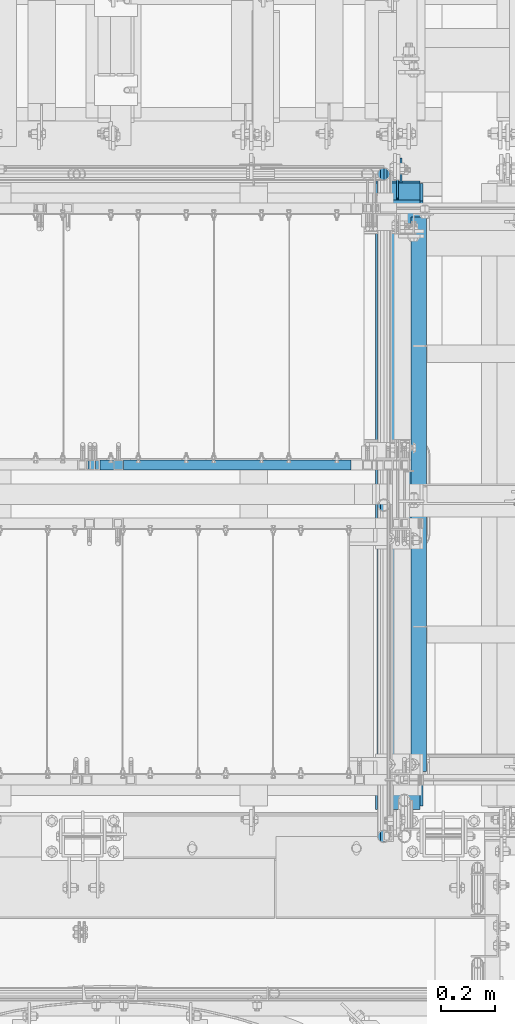
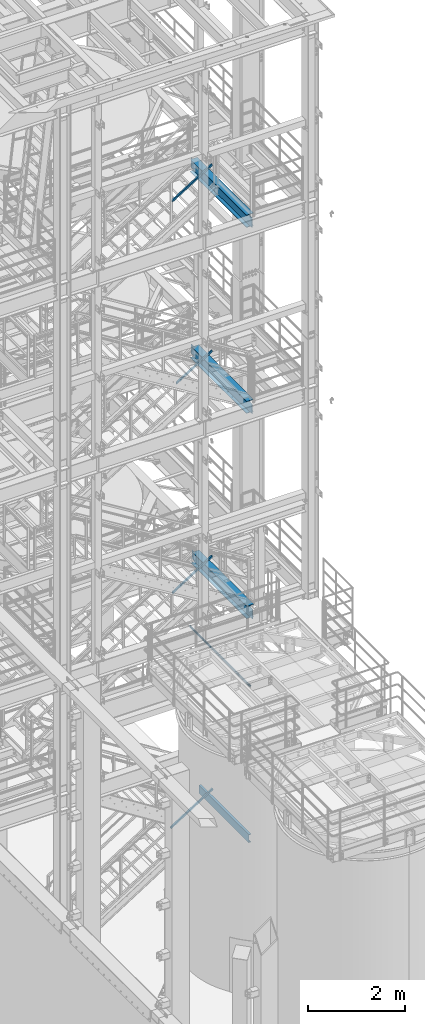
# One storey, part 984 of 1876: 5 beams, 4 members, 9 elements without a shape of their own.
"""IFC2X3 building model written with IfcOpenShell, lengths in millimetres."""

from ifc_helpers import new_model, si_unit, frame, origin_with_axes, place, context, subcontext, project, spatial, faceted_brep, material, type_object, element, aggregate, save


model = new_model("IFC2X3")

# Units and contexts
model_context = context("Model", 3, precision=1e-05, world=origin_with_axes())
body_context = subcontext(model_context, "Body", "Model", "MODEL_VIEW")
ifc_project = project(units=[si_unit("LENGTHUNIT", "METRE", prefix="MILLI"), si_unit("AREAUNIT", "SQUARE_METRE"), si_unit("VOLUMEUNIT", "CUBIC_METRE"), si_unit("MASSUNIT", "GRAM", prefix="KILO"), si_unit("TIMEUNIT", "SECOND"), si_unit("PLANEANGLEUNIT", "RADIAN"), si_unit("SOLIDANGLEUNIT", "STERADIAN"), si_unit("THERMODYNAMICTEMPERATUREUNIT", "DEGREE_CELSIUS"), si_unit("LUMINOUSINTENSITYUNIT", "LUMEN")], contexts=[model_context])

# Site, building, storey
site_placement = place(None, origin_with_axes())
site = spatial("IfcSite", under=ifc_project, at=site_placement, CompositionType="ELEMENT")
building_placement = place(site_placement, origin_with_axes())
building = spatial("IfcBuilding", under=site, at=building_placement, Name="Undefined", CompositionType="ELEMENT")
storey_placement = place(building_placement, origin_with_axes())
storey = spatial("IfcBuildingStorey", under=building, at=storey_placement, Name="Undefined", CompositionType="ELEMENT", Elevation=0.0)

# Assembly, beam
assembly_1_placement = place(storey_placement, origin_with_axes())
assembly_1 = element("IfcElementAssembly", 1, at=assembly_1_placement, inside=storey, Name="RAIL", AssemblyPlace="NOTDEFINED", PredefinedType="RIGID_FRAME")
ifc_material_1 = material()
beam_type_1 = type_object("IfcBeamType", Name="PIPE1-1/2SCH40", PredefinedType="NOTDEFINED")
beam_1_placement = place(assembly_1_placement, frame((6197.59999999994, -7136.13000000001, 6207.125), z_axis=(0.0, 0.0, -1.0), x_axis=(0.0, 1.0, 0.0)))
beam_1 = element("IfcBeam", 2, at=beam_1_placement, type_object=beam_type_1, material=ifc_material_1, Name="RAIL", ObjectType="PIPE1-1/2SCH40", context=body_context, shape_type="Brep", body=[
    faceted_brep([(24.1300000000001, -20.4469999999999, 0.0), (34.3535000000002, -17.7076214311803, 10.2235000000001), (2471.35649885447, -17.7076214311801, 10.2235000000001), (2481.57999885447, -20.4470000000001, 0.0), (41.8376214311802, -10.2235000000001, 17.7076214311819), (2463.87237742329, -10.2235000000001, 17.7076214311801), (44.5770000000002, 0.0, 20.4470000000001), (2461.13299885447, 0.0, 20.4470000000001), (41.8376214311802, 10.2235000000001, 17.7076214311819), (2463.87237742329, 10.2235000000001, 17.7076214311801), (34.3535000000002, 17.7076214311803, 10.2235000000001), (2471.35649885447, 17.7076214311801, 10.2235000000001), (24.1300000000001, 20.4469999999999, 0.0), (2481.57999885447, 20.4470000000001, 0.0), (13.9065000000001, 17.7076214311803, -10.2235000000001), (2491.80349885447, 17.7076214311801, -10.2235000000001), (6.42237856882002, 10.2235000000001, -17.7076214311819), (2499.28762028565, 10.2235000000001, -17.7076214311801), (3.68299999999999, 0.0, -20.4470000000001), (2502.02699885447, 0.0, -20.4470000000001), (6.42237856882002, -10.2235000000001, -17.7076214311819), (2499.28762028565, -10.2235000000001, -17.7076214311801), (13.9065000000001, -17.7076214311803, -10.2235000000001), (2491.80349885447, -17.7076214311801, -10.2235000000001), (24.1299999999854, -24.1299999999992, 0.0), (12.0650000000064, -20.8971929933177, -12.0649999999987), (2493.64499885447, -20.8971929933186, -12.0649999999996), (2481.57999885447, -24.1300000000001, 0.0), (3.23280700668147, -12.0650000000001, -20.8971929933177), (2502.47719184779, -12.0649999999996, -20.8971929933186), (-1.45519152283669e-11, 0.0, -24.130000000001), (2505.70999885447, 0.0, -24.1300000000001), (3.23280700668147, 12.0650000000001, -20.8971929933177), (2502.47719184779, 12.0649999999996, -20.8971929933186), (12.0650000000064, 20.8971929933177, -12.0649999999987), (2493.64499885447, 20.8971929933186, -12.0649999999996), (24.1300000000047, 24.1299999999992, 0.0), (2481.57999885447, 24.1300000000001, 0.0), (36.1949999999997, 20.8971929933184, 12.0649999999987), (2469.51499885447, 20.8971929933186, 12.0649999999996), (45.0271929933187, 12.0650000000001, 20.8971929933177), (2460.68280586115, 12.0649999999996, 20.8971929933186), (48.2600000000002, 0.0, 24.130000000001), (2457.44999885447, 0.0, 24.1300000000001), (45.0271929933187, -12.0650000000001, 20.8971929933177), (2460.68280586115, -12.0649999999996, 20.8971929933186), (36.1949999999997, -20.8971929933184, 12.0649999999987), (2469.51499885447, -20.8971929933186, 12.0649999999996)], [[[0, 1, 2, 3]], [[1, 4, 5, 2]], [[4, 6, 7, 5]], [[6, 8, 9, 7]], [[8, 10, 11, 9]], [[10, 12, 13, 11]], [[12, 14, 15, 13]], [[14, 16, 17, 15]], [[16, 18, 19, 17]], [[18, 20, 21, 19]], [[20, 22, 23, 21]], [[22, 0, 3, 23]], [[24, 25, 26, 27]], [[25, 28, 29, 26]], [[28, 30, 31, 29]], [[30, 32, 33, 31]], [[32, 34, 35, 33]], [[34, 36, 37, 35]], [[36, 38, 39, 37]], [[38, 40, 41, 39]], [[40, 42, 43, 41]], [[42, 44, 45, 43]], [[44, 46, 47, 45]], [[46, 24, 27, 47]], [[29, 31, 33, 35, 37, 39, 41, 43, 45, 47, 27, 26], [5, 7, 9, 11, 13, 15, 17, 19, 21, 23, 3, 2]], [[46, 44, 42, 40, 38, 36, 34, 32, 30, 28, 25, 24], [22, 20, 18, 16, 14, 12, 10, 8, 6, 4, 1, 0]]]),
])
aggregate(assembly_1, [beam_1])

assembly_2_placement = place(storey_placement, origin_with_axes())
assembly_2 = element("IfcElementAssembly", 3, at=assembly_2_placement, inside=storey, Name="STRINGER", AssemblyPlace="NOTDEFINED", PredefinedType="RIGID_FRAME")
ifc_material_2 = material(Name="STEEL/A36")
beam_type_2 = type_object("IfcBeamType", Name="C8X11.5", PredefinedType="NOTDEFINED")
beam_2_placement = place(assembly_2_placement, frame((6327.77500038161, -6883.40000113304, 2196.42941810345), z_axis=(0.0, 0.0, 1.0), x_axis=(0.0, 1.0, 0.0)))
beam_2 = element("IfcBeam", 4, at=beam_2_placement, type_object=beam_type_2, material=ifc_material_2, Name="STRINGER", ObjectType="C8X11.5", context=body_context, shape_type="Brep", body=[
    faceted_brep([(12.7000000000007, 28.5749999999998, -101.6), (12.7000000000007, 28.5749999999998, 101.6), (2070.09999991865, 28.5749999999998, 101.6), (2070.09999991865, 28.5749999999998, -101.6), (12.7000000000007, -28.5749999999998, 101.6), (2070.09999991865, -28.5749999999998, 101.6), (12.7000000000007, -28.5749999999998, 96.8355949999996), (2070.09999991865, -28.5749999999998, 96.835595), (12.7000000000007, 22.2250000000004, 88.3723149999996), (2070.09999991865, 22.2250000000004, 88.3723150000001), (12.7000000000007, 22.2250000000004, -88.3723149999996), (2070.09999991865, 22.2250000000004, -88.3723150000001), (12.7000000000007, -28.5749999999998, -96.8355949999996), (2070.09999991865, -28.5749999999998, -96.835595), (12.7000000000007, -28.5749999999998, -101.6), (2070.09999991865, -28.5749999999998, -101.6)], [[[0, 1, 2, 3]], [[1, 4, 5, 2]], [[4, 6, 7, 5]], [[6, 8, 9, 7]], [[8, 10, 11, 9]], [[10, 12, 13, 11]], [[12, 14, 15, 13]], [[14, 0, 3, 15]], [[5, 7, 9, 11, 13, 15, 3, 2]], [[14, 12, 10, 8, 6, 4, 1, 0]]]),
])
aggregate(assembly_2, [beam_2])

# Assembly, member
assembly_3_placement = place(storey_placement, origin_with_axes())
assembly_3 = element("IfcElementAssembly", 5, at=assembly_3_placement, inside=storey, Name="RAIL", AssemblyPlace="NOTDEFINED", PredefinedType="RIGID_FRAME")
ifc_material_3 = material()
member_type = type_object("IfcMemberType", Name="HSS1-1/2X1-1/2X1/8", PredefinedType="NOTDEFINED")
member_1_placement = place(assembly_3_placement, frame((5080.00000001329, -5734.05000114554, 2193.12876147334), z_axis=(-0.53569741975471, 0.0, 0.844410015613355), x_axis=(0.844410015326383, 0.0, 0.535697420207059)))
member_1 = element("IfcMember", 6, at=member_1_placement, type_object=member_type, material=ifc_material_3, Name="RAIL", ObjectType="HSS1-1/2X1-1/2X1/8", context=body_context, shape_type="Brep", body=[
    faceted_brep([(12.4889602027924, 15.8749992829999, -15.8749992829981), (12.4889602027924, -15.8749992829999, -15.8749992829981), (1198.5961562867, -15.8749992829999, -15.874999282681), (1198.5961562867, 15.8749992829999, -15.874999282681), (32.6312986338025, -15.8749992829999, 15.8749992830109), (1207.81774592547, -15.8749992829999, 15.8749992833251), (32.6312986338025, 15.8749992829999, 15.8749992830109), (1207.81774592547, 15.8749992829999, 15.8749992833251), (10.4747262991696, 19.0499992349996, -19.0499992349991), (34.6455325374254, 19.0499992349996, 19.049999235012), (1208.73990491706, 19.0499992349996, 19.0499992353258), (1197.67399729511, 19.0499992349996, -19.0499992346821), (34.6455325374254, -19.0499992349996, 19.049999235012), (1208.73990491706, -19.0499992349996, 19.0499992353258), (10.4747262991696, -19.0499992349996, -19.0499992349991), (1197.67399729511, -19.0499992349996, -19.0499992346821)], [[[0, 1, 2, 3]], [[1, 4, 5, 2]], [[4, 6, 7, 5]], [[6, 0, 3, 7]], [[8, 9, 10, 11]], [[9, 12, 13, 10]], [[12, 14, 15, 13]], [[14, 8, 11, 15]], [[13, 15, 11, 10], [5, 7, 3, 2]], [[14, 12, 9, 8], [6, 4, 1, 0]]]),
])
aggregate(assembly_3, [member_1])

assembly_4_placement = place(storey_placement, origin_with_axes())
assembly_4 = element("IfcElementAssembly", 7, at=assembly_4_placement, inside=storey, Name="RAIL", AssemblyPlace="NOTDEFINED", PredefinedType="RIGID_FRAME")
member_2_placement = place(assembly_4_placement, frame((5124.4499953538, -5734.05000114554, 8078.06590455734), z_axis=(-0.536875491934336, 0.0, 0.843661487896813), x_axis=(0.843661487896813, 0.0, 0.536875491934336)))
member_2 = element("IfcMember", 8, at=member_2_placement, type_object=member_type, material=ifc_material_3, Name="RAIL", ObjectType="HSS1-1/2X1-1/2X1/8", context=body_context, shape_type="Brep", body=[
    faceted_brep([(12.4778733370622, 15.8749992829999, -15.8749992829939), (12.4778733370622, -15.8749992829999, -15.8749992829939), (1129.22312611781, -15.8749992829999, -15.8749992825997), (1129.22312611781, 15.8749992829999, -15.8749992825997), (32.6824178653787, -15.8749992829999, 15.8749992830085), (1138.46874750438, -15.8749992829999, 15.8749992834), (32.6824178653787, 15.8749992829999, 15.8749992830085), (1138.46874750438, 15.8749992829999, 15.8749992834), (10.4574188235219, 19.0499992349996, -19.0499992349946), (34.7028723789208, 19.0499992349996, 19.0499992350083), (1139.39330967082, 19.0499992349996, 19.0499992353994), (1128.29856395138, 19.0499992349996, -19.0499992345995), (34.7028723789208, -19.0499992349996, 19.0499992350083), (1139.39330967082, -19.0499992349996, 19.0499992353994), (10.4574188235219, -19.0499992349996, -19.0499992349946), (1128.29856395138, -19.0499992349996, -19.0499992345995)], [[[0, 1, 2, 3]], [[1, 4, 5, 2]], [[4, 6, 7, 5]], [[6, 0, 3, 7]], [[8, 9, 10, 11]], [[9, 12, 13, 10]], [[12, 14, 15, 13]], [[14, 8, 11, 15]], [[13, 15, 11, 10], [5, 7, 3, 2]], [[14, 12, 9, 8], [6, 4, 1, 0]]]),
])
aggregate(assembly_4, [member_2])

assembly_5_placement = place(storey_placement, origin_with_axes())
assembly_5 = element("IfcElementAssembly", 9, at=assembly_5_placement, inside=storey, Name="RAIL", AssemblyPlace="NOTDEFINED", PredefinedType="RIGID_FRAME")
member_3_placement = place(assembly_5_placement, frame((5213.35000009579, -5734.05000114554, 13309.5615150425), z_axis=(-0.523953411146183, 0.0, 0.851746924237639), x_axis=(0.851746924237639, 0.0, 0.523953411146184)))
member_3 = element("IfcMember", 10, at=member_3_placement, type_object=member_type, material=ifc_material_3, Name="RAIL", ObjectType="HSS1-1/2X1-1/2X1/8", context=body_context, shape_type="Brep", body=[
    faceted_brep([(12.6002676416374, 15.8749992829999, -15.8749992830035), (12.6002676416374, -15.8749992829999, -15.8749992830035), (1013.61105050611, -15.8749992829999, -15.8749992832345), (1013.61105050611, 15.8749992829999, -15.8749992832345), (32.1313273721225, -15.8749992829999, 15.874999282998), (1022.5947403588, -15.8749992829999, 15.8749992827688), (32.1313273721225, 15.8749992829999, 15.874999282998), (1022.5947403588, 15.8749992829999, 15.8749992827688), (10.6471616099025, 19.0499992349996, -19.0499992350033), (34.0844334038557, 19.0499992349996, 19.0499992349978), (1023.49310937106, 19.0499992349996, 19.0499992347686), (1012.71268149385, 19.0499992349996, -19.0499992352343), (34.0844334038557, -19.0499992349996, 19.0499992349978), (1023.49310937106, -19.0499992349996, 19.0499992347686), (10.6471616099025, -19.0499992349996, -19.0499992350033), (1012.71268149385, -19.0499992349996, -19.0499992352343)], [[[0, 1, 2, 3]], [[1, 4, 5, 2]], [[4, 6, 7, 5]], [[6, 0, 3, 7]], [[8, 9, 10, 11]], [[9, 12, 13, 10]], [[12, 14, 15, 13]], [[14, 8, 11, 15]], [[13, 15, 11, 10], [5, 7, 3, 2]], [[14, 12, 9, 8], [6, 4, 1, 0]]]),
])
aggregate(assembly_5, [member_3])

assembly_6_placement = place(storey_placement, origin_with_axes())
assembly_6 = element("IfcElementAssembly", 11, at=assembly_6_placement, inside=storey, Name="RAIL", AssemblyPlace="NOTDEFINED", PredefinedType="RIGID_FRAME")
member_4_placement = place(assembly_6_placement, frame((5107.78124790234, -5734.05000114554, 17913.9321244588), z_axis=(-0.526627379729772, 0.0, 0.850096231563789), x_axis=(0.850096231563789, 0.0, 0.526627379729772)))
member_4 = element("IfcMember", 12, at=member_4_placement, type_object=member_type, material=ifc_material_3, Name="RAIL", ObjectType="HSS1-1/2X1-1/2X1/8", context=body_context, shape_type="Brep", body=[
    faceted_brep([(12.574799847971, 15.8749992829999, -15.8749992829671), (12.574799847971, -15.8749992829999, -15.8749992829671), (1139.87266300767, -15.8749992829999, -15.8749992813318), (1139.87266300767, 15.8749992829999, -15.8749992813318), (32.243653714735, -15.8749992829999, 15.8749992830344), (1148.91025696958, -15.8749992829999, 15.8749992846551), (32.243653714735, 15.8749992829999, 15.8749992830344), (1148.91025696958, 15.8749992829999, 15.8749992846551), (10.6079144021951, 19.0499992349996, -19.0499992349669), (34.210539160511, 19.0499992349996, 19.0499992350342), (1149.81401639293, 19.0499992349996, 19.0499992366531), (1138.96890358432, 19.0499992349996, -19.0499992333316), (34.210539160511, -19.0499992349996, 19.0499992350342), (1149.81401639293, -19.0499992349996, 19.0499992366531), (10.6079144021951, -19.0499992349996, -19.0499992349669), (1138.96890358432, -19.0499992349996, -19.0499992333316)], [[[0, 1, 2, 3]], [[1, 4, 5, 2]], [[4, 6, 7, 5]], [[6, 0, 3, 7]], [[8, 9, 10, 11]], [[9, 12, 13, 10]], [[12, 14, 15, 13]], [[14, 8, 11, 15]], [[13, 15, 11, 10], [5, 7, 3, 2]], [[14, 12, 9, 8], [6, 4, 1, 0]]]),
])
aggregate(assembly_6, [member_4])

# Assembly, beam
assembly_7_placement = place(storey_placement, origin_with_axes())
assembly_7 = element("IfcElementAssembly", 13, at=assembly_7_placement, inside=storey, Name="BEAM", AssemblyPlace="NOTDEFINED", PredefinedType="RIGID_FRAME")
ifc_material_4 = material(Name="STEEL/A992")
beam_type_3 = type_object("IfcBeamType", Name="W12X30", PredefinedType="NOTDEFINED")
beam_3_placement = place(assembly_7_placement, frame((6248.4, -7112.0, 17826.0375), z_axis=(0.0, 0.0, 1.0), x_axis=(0.0, 1.0, 0.0)))
beam_3 = element("IfcBeam", 14, at=beam_3_placement, type_object=beam_type_3, material=ifc_material_4, Name="BEAM", ObjectType="W12X30", context=body_context, shape_type="Brep", body=[
    faceted_brep([(17.4624999999996, -3.17500000000018, -131.762500000004), (17.4624999999996, 3.17500000000018, -131.762500000004), (93.6625001907341, 3.17500002465476, -131.762500000004), (93.6625001907341, -3.17500000000018, -131.762500000004), (98.5225797087796, 3.1750000248112, -132.729229922592), (98.5225797087796, -3.17500000000018, -132.729229922592), (102.642756176933, 3.17500002525321, -135.482243823069), (102.642756176933, -3.17500000000018, -135.482243823069), (105.395770077412, 3.1750000259135, -139.602420291223), (105.395770077412, -3.17500000000018, -139.602420291223), (106.362499999999, -3.17500000000018, -144.46249980927), (106.362499999999, 3.17500002669112, -144.46249980927), (106.362499999999, 3.17500009484957, -146.049999999999), (106.362499999999, 82.5500000000002, -146.049999999999), (106.362499999999, 82.5500000000002, -157.162499999999), (106.362499999999, -82.5500000000002, -157.162499999999), (106.362499999999, -82.5500000000002, -146.049999999999), (106.362499999999, -3.17500000000018, -146.049999999999), (2413.79375, 82.5500000000002, 146.049999999999), (2413.79375, 3.17500000000018, 146.049999999999), (106.362499999999, 3.17500000000018, 146.049999999999), (106.362499999999, 82.5500000000002, 146.049999999999), (93.6625001907341, -3.17500000000018, 125.412499999995), (93.6625001907341, 3.17499998419134, 125.412499999995), (17.4624999999996, 3.17500000000018, 125.412499999995), (17.4624999999996, -3.17500000000018, 125.412499999995), (98.5225797087796, -3.17500000000018, 126.379229922582), (98.5225797087796, 3.17499998403764, 126.379229922582), (102.642756176933, -3.17500000000018, 129.13224382306), (102.642756176933, 3.17499998359926, 129.13224382306), (105.395770077412, -3.17500000000018, 133.252420291214), (105.395770077412, 3.17499998294261, 133.252420291214), (106.362499999999, -3.17500000000018, 138.11249980926), (106.362499999999, 3.17499998216772, 138.11249980926), (2413.79375, -82.5500000000002, 157.162499999999), (2413.79375, 82.5500000000002, 157.162499999999), (106.362499999999, 82.5500000000002, 157.162499999999), (106.362499999999, -82.5500000000002, 157.162499999999), (2413.79375, -82.5500000000002, 146.049999999999), (106.362499999999, -82.5500000000002, 146.049999999999), (2413.79375, -3.17500000000018, 146.049999999999), (106.362499999999, -3.17500000000018, 146.049999999999), (2413.79375, -3.17500000000018, 125.41249980927), (2413.79375, 3.17500000000018, 125.41249980927), (2414.76047992259, -3.17500000000018, 120.552420291224), (2414.76047992259, 3.17500000000018, 120.552420291224), (2417.51349382307, -3.17500000000018, 116.43224382307), (2417.51349382307, 3.17500000000018, 116.43224382307), (2421.63367029122, -3.17500000000018, 113.679229922593), (2421.63367029122, 3.17500000000018, 113.679229922593), (2426.49374980926, -3.17500000000018, 112.712500000005), (2426.49374980926, 3.17500000000018, 112.712500000005), (2520.15625, -3.17500000000018, 112.712500000005), (2520.15625, 3.17500000000018, 112.712500000005), (2520.15625, -3.17500000000018, -131.762499999993), (2520.15625, 3.17500000000018, -131.762499999993), (2443.95624980927, -3.17500000000018, -131.762499999993), (2443.95624980927, 3.17500000000018, -131.762499999993), (2439.09617029122, -3.17500000000018, -132.729229922581), (2439.09617029122, 3.17500000000018, -132.729229922581), (2434.97599382307, -3.17500000000018, -135.482243823059), (2434.97599382307, 3.17500000000018, -135.482243823059), (2432.22297992259, -3.17500000000018, -139.602420291212), (2432.22297992259, 3.17500000000018, -139.602420291212), (2431.25625, -3.17500000000018, -144.462499809259), (2431.25625, 3.17500000000018, -144.462499809259), (2431.25625, -3.17500000000018, -146.049999999999), (2431.25625, -82.5500000000002, -146.049999999999), (2431.25625, -82.5500000000002, -157.162499999999), (2431.25625, 82.5500000000002, -157.162499999999), (2431.25625, 82.5500000000002, -146.049999999999), (2431.25625, 3.17500000000018, -146.049999999999)], [[[0, 1, 2, 3]], [[3, 2, 4, 5]], [[5, 4, 6, 7]], [[7, 6, 8, 9]], [[10, 11, 12, 13, 14, 15, 16, 17]], [[9, 8, 11, 10]], [[18, 19, 20, 21]], [[22, 23, 24, 25]], [[26, 27, 23, 22]], [[28, 29, 27, 26]], [[30, 31, 29, 28]], [[32, 33, 31, 30]], [[34, 35, 36, 37]], [[38, 34, 37, 39]], [[40, 38, 39, 41]], [[37, 36, 21, 20, 33, 32, 41, 39]], [[35, 18, 21, 36]], [[34, 38, 40, 42, 43, 19, 18, 35]], [[44, 45, 43, 42]], [[46, 47, 45, 44]], [[48, 49, 47, 46]], [[50, 51, 49, 48]], [[52, 53, 51, 50]], [[53, 52, 54, 55]], [[54, 56, 57, 55]], [[58, 59, 57, 56]], [[60, 61, 59, 58]], [[62, 63, 61, 60]], [[64, 65, 63, 62]], [[66, 67, 68, 69, 70, 71, 65, 64]], [[67, 66, 17, 16]], [[68, 67, 16, 15]], [[69, 68, 15, 14]], [[70, 69, 14, 13]], [[71, 70, 13, 12]], [[6, 4, 2, 1, 24, 23, 27, 29, 31, 33, 20, 19, 43, 45, 47, 49, 51, 53, 55, 57, 59, 61, 63, 65, 71, 12, 11, 8]], [[25, 24, 1, 0]], [[66, 64, 62, 60, 58, 56, 54, 52, 50, 48, 46, 44, 42, 40, 41, 32, 30, 28, 26, 22, 25, 0, 3, 5, 7, 9, 10, 17]]]),
])
aggregate(assembly_7, [beam_3])

assembly_8_placement = place(storey_placement, origin_with_axes())
assembly_8 = element("IfcElementAssembly", 15, at=assembly_8_placement, inside=storey, Name="BEAM", AssemblyPlace="NOTDEFINED", PredefinedType="RIGID_FRAME")
beam_4_placement = place(assembly_8_placement, frame((6248.4, -7112.0, 13152.4375), z_axis=(0.0, 0.0, 1.0), x_axis=(0.0, 1.0, 0.0)))
beam_4 = element("IfcBeam", 16, at=beam_4_placement, type_object=beam_type_3, material=ifc_material_4, Name="BEAM", ObjectType="W12X30", context=body_context, shape_type="Brep", body=[
    faceted_brep([(2424.1125, -3.17500000000018, -146.049999999999), (2424.1125, -82.5500000000002, -146.049999999999), (2424.1125, -82.5500000000002, -157.1625), (2424.1125, 82.5500000000002, -157.1625), (2424.1125, 82.5500000000002, -146.049999999999), (2424.1125, 3.17500000000018, -146.049999999999), (2424.1125, 3.17500000000018, -144.462499809264), (2424.1125, -3.17500000000018, -144.462499809264), (2425.07922992259, 3.17500000000018, -139.602420291218), (2425.07922992259, -3.17500000000018, -139.602420291218), (2427.83224382307, 3.17500000000018, -135.482243823064), (2427.83224382307, -3.17500000000018, -135.482243823064), (2431.95242029122, 3.17500000000018, -132.729229922586), (2431.95242029122, -3.17500000000018, -132.729229922586), (2436.81249980927, 3.17500000000018, -131.762499999999), (2436.81249980927, -3.17500000000018, -131.762499999999), (2519.3625, -3.17500000000018, -131.762499999999), (2519.3625, 3.17500000000018, -131.762499999999), (100.012500000001, 3.17500000000018, 146.049999999999), (100.012500000001, 82.5500000000002, 146.049999999999), (2360.6125, 82.5500000000002, 146.049999999999), (2360.6125, 3.17500000000018, 146.049999999999), (112.712500000001, -3.17500000000018, -144.462499809266), (112.712500000001, 3.17500000000018, -144.462499809266), (112.712500000001, 3.17500000000018, -146.049999999999), (112.712500000001, 82.5500000000002, -146.049999999999), (112.712500000001, 82.5500000000002, -157.1625), (112.712500000001, -82.5500000000002, -157.1625), (112.712500000001, -82.5500000000002, -146.049999999999), (112.712500000001, -3.17500000000018, -146.049999999999), (111.745770077413, -3.17500000000018, -139.602420291219), (111.745770077413, 3.17500000000018, -139.602420291219), (108.992756176935, -3.17500000000018, -135.482243823066), (108.992756176935, 3.17500000000018, -135.482243823066), (104.872579708781, -3.17500000000018, -132.729229922588), (104.872579708781, 3.17500000000018, -132.729229922588), (100.012500190735, -3.17500000000018, -131.762500000001), (100.012500190735, 3.17500000000018, -131.762500000001), (17.4624999999996, -3.17500000000018, -131.762500000004), (17.4624999999996, 3.17500000000018, -131.762500000004), (17.4624999999996, -3.17500000000018, 119.0625), (17.4624999999996, 3.17500000000018, 119.0625), (87.3125001907356, -3.17500000000018, 119.0625), (87.3125001907356, 3.17500000000018, 119.0625), (92.1725797087811, -3.17500000000018, 120.029229922588), (92.1725797087811, 3.17500000000018, 120.029229922588), (96.2927561769347, -3.17500000000018, 122.782243823065), (96.2927561769347, 3.17500000000018, 122.782243823065), (99.0457700774132, -3.17500000000018, 126.902420291219), (99.0457700774132, 3.17500000000018, 126.902420291219), (100.012500000001, -3.17500000000018, 131.762499809265), (100.012500000001, 3.17500000000018, 131.762499809265), (100.012500000001, -82.5500000000002, 157.1625), (100.012500000001, 82.5500000000002, 157.1625), (100.012500000001, -3.17500000000018, 146.049999999999), (100.012500000001, -82.5500000000002, 146.049999999999), (2360.6125, -3.17500000000018, 146.049999999999), (2360.6125, -82.5500000000002, 146.049999999999), (2360.6125, -82.5500000000002, 157.1625), (2360.6125, 82.5500000000002, 157.1625), (2360.6125, -3.17500000000018, 119.062499809266), (2360.6125, 3.17500000000018, 119.062499809266), (2361.57922992259, -3.17500000000018, 114.20242029122), (2361.57922992259, 3.17500000000018, 114.20242029122), (2364.33224382307, -3.17500000000018, 110.082243823066), (2364.33224382307, 3.17500000000018, 110.082243823066), (2368.45242029122, -3.17500000000018, 107.329229922589), (2368.45242029122, 3.17500000000018, 107.329229922589), (2373.31249980927, -3.17500000000018, 106.362500000001), (2373.31249980927, 3.17500000000018, 106.362500000001), (2519.3625, -3.17500000000018, 106.362500000001), (2519.3625, 3.17500000000018, 106.362500000001)], [[[0, 1, 2, 3, 4, 5, 6, 7]], [[7, 6, 8, 9]], [[9, 8, 10, 11]], [[11, 10, 12, 13]], [[13, 12, 14, 15]], [[16, 15, 14, 17]], [[18, 19, 20, 21]], [[22, 23, 24, 25, 26, 27, 28, 29]], [[30, 31, 23, 22]], [[32, 33, 31, 30]], [[34, 35, 33, 32]], [[36, 37, 35, 34]], [[38, 39, 37, 36]], [[40, 41, 39, 38]], [[42, 43, 41, 40]], [[44, 45, 43, 42]], [[46, 47, 45, 44]], [[48, 49, 47, 46]], [[50, 51, 49, 48]], [[52, 53, 19, 18, 51, 50, 54, 55]], [[55, 54, 56, 57]], [[52, 55, 57, 58]], [[53, 52, 58, 59]], [[19, 53, 59, 20]], [[58, 57, 56, 60, 61, 21, 20, 59]], [[62, 63, 61, 60]], [[64, 65, 63, 62]], [[66, 67, 65, 64]], [[68, 69, 67, 66]], [[70, 71, 69, 68]], [[71, 70, 16, 17]], [[12, 10, 8, 6, 5, 24, 23, 31, 33, 35, 37, 39, 41, 43, 45, 47, 49, 51, 18, 21, 61, 63, 65, 67, 69, 71, 17, 14]], [[25, 24, 5, 4]], [[26, 25, 4, 3]], [[27, 26, 3, 2]], [[28, 27, 2, 1]], [[29, 28, 1, 0]], [[70, 68, 66, 64, 62, 60, 56, 54, 50, 48, 46, 44, 42, 40, 38, 36, 34, 32, 30, 22, 29, 0, 7, 9, 11, 13, 15, 16]]]),
])
aggregate(assembly_8, [beam_4])

assembly_9_placement = place(storey_placement, origin_with_axes())
assembly_9 = element("IfcElementAssembly", 17, at=assembly_9_placement, inside=storey, Name="BEAM", AssemblyPlace="NOTDEFINED", PredefinedType="RIGID_FRAME")
beam_5_placement = place(assembly_9_placement, frame((6261.1, -7112.0, 7996.2375), z_axis=(0.0, 0.0, 1.0), x_axis=(0.0, 1.0, 0.0)))
beam_5 = element("IfcBeam", 18, at=beam_5_placement, type_object=beam_type_3, material=ifc_material_4, Name="BEAM", ObjectType="W12X30", context=body_context, shape_type="Brep", body=[
    faceted_brep([(17.4624999999996, -3.17500000000018, -131.762500000004), (17.4624999999996, 3.17500000000018, -131.762500000004), (100.012500190735, 3.17500000000018, -131.762500000001), (100.012500190735, -3.17500000000018, -131.762500000001), (104.872579708781, 3.17500000000018, -132.729229922588), (104.872579708781, -3.17500000000018, -132.729229922588), (108.992756176935, 3.17500000000018, -135.482243823066), (108.992756176935, -3.17500000000018, -135.482243823066), (111.745770077413, 3.17500000000018, -139.602420291219), (111.745770077413, -3.17500000000018, -139.602420291219), (112.712500000001, -3.17500000000018, -144.462499809266), (112.712500000001, 3.17500000000018, -144.462499809266), (112.712500000001, 3.17500000000018, -146.049999999999), (112.712500000001, 82.5500000000002, -146.049999999999), (112.712500000001, 82.5500000000002, -157.1625), (112.712500000001, -82.5500000000002, -157.1625), (112.712500000001, -82.5500000000002, -146.049999999999), (112.712500000001, -3.17500000000018, -146.049999999999), (2358.23125, 82.5500000000002, 146.05), (2358.23125, 3.17500000000018, 146.05), (112.712500000001, 3.17500000000018, 146.05), (112.712500000001, 82.5500000000002, 146.05), (100.012500190735, -3.17500000000018, 119.062500000001), (100.012500190735, 3.17500000000018, 119.062500000001), (17.4624999999996, 3.17500000000018, 119.0625), (17.4624999999996, -3.17500000000018, 119.0625), (104.872579708781, -3.17500000000018, 120.029229922588), (104.872579708781, 3.17500000000018, 120.029229922588), (108.992756176935, -3.17500000000018, 122.782243823067), (108.992756176935, 3.17500000000018, 122.782243823067), (111.745770077413, -3.17500000000018, 126.902420291221), (111.745770077413, 3.17500000000018, 126.902420291221), (112.712500000001, -3.17500000000018, 131.762499809266), (112.712500000001, 3.17500000000018, 131.762499809266), (2358.23125, -82.5500000000002, 157.1625), (2358.23125, 82.5500000000002, 157.1625), (112.712500000001, 82.5500000000002, 157.1625), (112.712500000001, -82.5500000000002, 157.1625), (2358.23125, -82.5500000000002, 146.05), (112.712500000001, -82.5500000000002, 146.05), (2358.23125, -3.17500000000018, 146.05), (112.712500000001, -3.17500000000018, 146.05), (2358.23125, -3.17500000000018, 119.062499809265), (2358.23125, 3.17500000000018, 119.062499809265), (2359.19797992259, -3.17500000000018, 114.20242029122), (2359.19797992259, 3.17500000000018, 114.20242029122), (2361.95099382307, -3.17500000000018, 110.082243823066), (2361.95099382307, 3.17500000000018, 110.082243823066), (2366.07117029122, -3.17500000000018, 107.329229922588), (2366.07117029122, 3.17500000000018, 107.329229922588), (2370.93124980927, -3.17500000000018, 106.3625), (2370.93124980927, 3.17500000000018, 106.3625), (2516.98125, -3.17500000000018, 106.3625), (2516.98125, 3.17500000000018, 106.3625), (2516.98125, -3.17500000000018, -131.7625), (2516.98125, 3.17500000000018, -131.7625), (2434.43124980927, -3.17500000000018, -131.7625), (2434.43124980927, 3.17500000000018, -131.7625), (2429.57117029122, -3.17500000000018, -132.729229922587), (2429.57117029122, 3.17500000000018, -132.729229922587), (2425.45099382307, -3.17500000000018, -135.482243823066), (2425.45099382307, 3.17500000000018, -135.482243823066), (2422.69797992259, -3.17500000000018, -139.602420291219), (2422.69797992259, 3.17500000000018, -139.602420291219), (2421.73125, -3.17500000000018, -144.462499809265), (2421.73125, 3.17500000000018, -144.462499809265), (2421.73125, -3.17500000000018, -146.05), (2421.73125, -82.5500000000002, -146.05), (2421.73125, -82.5500000000002, -157.1625), (2421.73125, 82.5500000000002, -157.1625), (2421.73125, 82.5500000000002, -146.05), (2421.73125, 3.17500000000018, -146.05)], [[[0, 1, 2, 3]], [[3, 2, 4, 5]], [[5, 4, 6, 7]], [[7, 6, 8, 9]], [[10, 11, 12, 13, 14, 15, 16, 17]], [[9, 8, 11, 10]], [[18, 19, 20, 21]], [[22, 23, 24, 25]], [[26, 27, 23, 22]], [[28, 29, 27, 26]], [[30, 31, 29, 28]], [[32, 33, 31, 30]], [[34, 35, 36, 37]], [[38, 34, 37, 39]], [[40, 38, 39, 41]], [[37, 36, 21, 20, 33, 32, 41, 39]], [[35, 18, 21, 36]], [[34, 38, 40, 42, 43, 19, 18, 35]], [[44, 45, 43, 42]], [[46, 47, 45, 44]], [[48, 49, 47, 46]], [[50, 51, 49, 48]], [[52, 53, 51, 50]], [[53, 52, 54, 55]], [[54, 56, 57, 55]], [[58, 59, 57, 56]], [[60, 61, 59, 58]], [[62, 63, 61, 60]], [[64, 65, 63, 62]], [[66, 67, 68, 69, 70, 71, 65, 64]], [[67, 66, 17, 16]], [[68, 67, 16, 15]], [[69, 68, 15, 14]], [[70, 69, 14, 13]], [[71, 70, 13, 12]], [[6, 4, 2, 1, 24, 23, 27, 29, 31, 33, 20, 19, 43, 45, 47, 49, 51, 53, 55, 57, 59, 61, 63, 65, 71, 12, 11, 8]], [[25, 24, 1, 0]], [[66, 64, 62, 60, 58, 56, 54, 52, 50, 48, 46, 44, 42, 40, 41, 32, 30, 28, 26, 22, 25, 0, 3, 5, 7, 9, 10, 17]]]),
])
aggregate(assembly_9, [beam_5])

save(model, "model.ifc")
